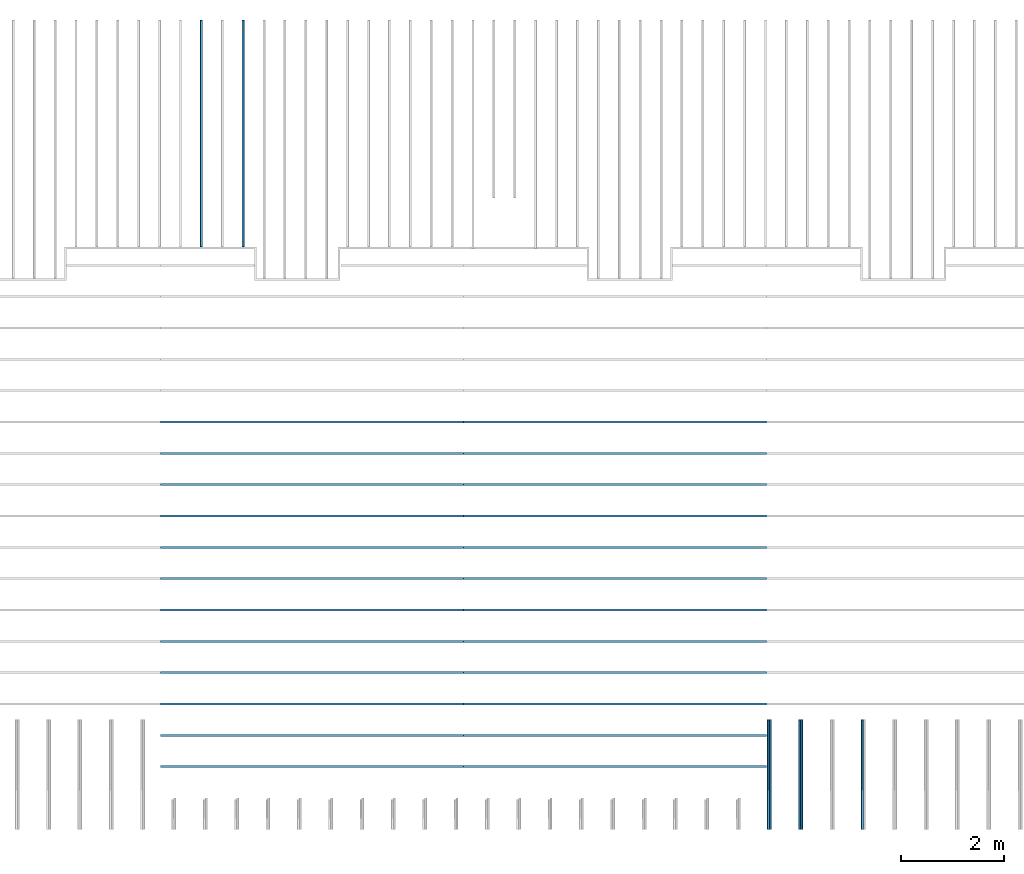
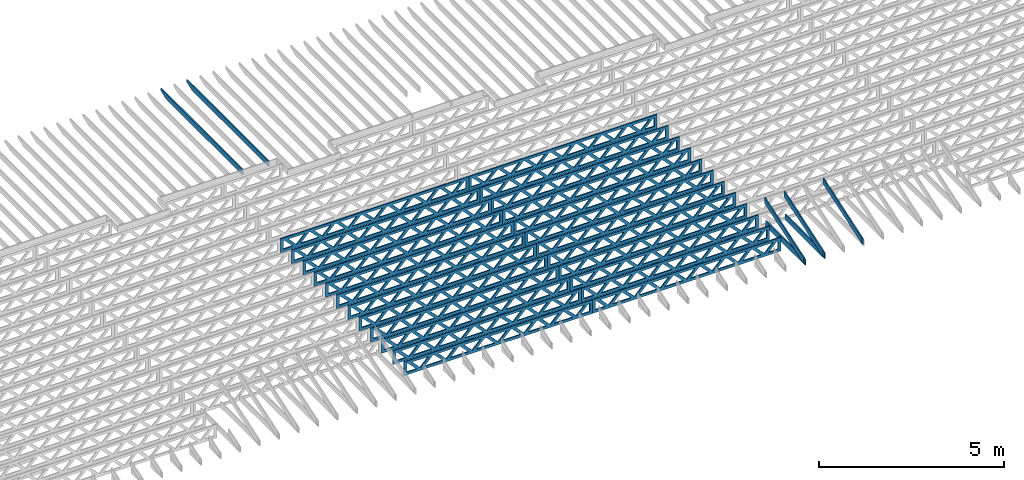
# One storey, part 7 of 18: 31 beams, 5 elements without a shape of their own.
"""IFC4 building model written with IfcOpenShell, lengths in feet."""

import ifcopenshell
import ifcopenshell.guid

model = None  # the IFC model being written
_history = None  # IfcOwnerHistory: only IFC2X3 demands one
_inside = {}  # id of a spatial element -> (the spatial element, [elements in it])
_under = {}  # id of a project, library or spatial element -> (it, [spatial elements below it])
_declared = {}  # id of a project -> (the project, [libraries it declares])
_typed = {}  # id of a type object -> (the type object, [elements of that type])
_made_of = {}  # id of a material, layer set ... -> (it, [elements and type objects made of it])


def new_model(schema):
    """Start an empty IFC model of exactly this schema.

    Asked for "IFC4X3", IfcOpenShell would pick the latest addendum, in which some entities
    have other attributes; the version numbers below select the first issue.
    IFC2X3 requires an IfcOwnerHistory on every rooted entity: one is made here for all.
    """
    global model, _history
    if schema == "IFC4X3":
        model = ifcopenshell.file(schema_version=(4, 3, 0, 0))
    else:
        model = ifcopenshell.file(schema=schema)
    _inside.clear()
    _under.clear()
    _declared.clear()
    _typed.clear()
    _made_of.clear()
    _history = None
    if model.schema == "IFC2X3":
        org = make("IfcOrganization", Name="unknown")
        user = make(
            "IfcPersonAndOrganization",
            ThePerson=make("IfcPerson", FamilyName="unknown"),
            TheOrganization=org,
        )
        app = make(
            "IfcApplication",
            ApplicationDeveloper=org,
            Version="unknown",
            ApplicationFullName="unknown",
            ApplicationIdentifier="unknown",
        )
        _history = make(
            "IfcOwnerHistory",
            OwningUser=user,
            OwningApplication=app,
            ChangeAction="ADDED",
            CreationDate=0,
        )
    return model


def make(cls, **values):
    """One entity of the class cls with the attributes given. An attribute that is None is left unset."""
    return model.create_entity(
        cls, **{name: value for name, value in values.items() if value is not None}
    )


def entity(cls, *values):
    """Any entity or typed value of the class cls, its attributes in the order of the schema. None: left unset."""
    e = model.create_entity(cls)
    for i, value in enumerate(values):
        if value is not None:
            e[i] = value
    return e


def rooted(cls, **values):
    """An entity with a GlobalId (a new one), such as an element, a storey or a relation."""
    return make(cls, GlobalId=ifcopenshell.guid.new(), OwnerHistory=_history, **values)


def si_unit(unit_type, name, prefix=None):
    """IfcSIUnit, for example si_unit("LENGTHUNIT", "METRE", prefix="MILLI")."""
    return make("IfcSIUnit", UnitType=unit_type, Prefix=prefix, Name=name)


def converted_unit(unit_type, name, factor, base, dimensions=None, offset=None):
    """IfcConversionBasedUnit, such as the inch: factor (a typed value) times the base unit."""
    return make(
        "IfcConversionBasedUnit"
        if offset is None
        else "IfcConversionBasedUnitWithOffset",
        ConversionOffset=offset,
        Dimensions=None
        if dimensions is None
        else entity("IfcDimensionalExponents", *dimensions),
        UnitType=unit_type,
        Name=name,
        ConversionFactor=make(
            "IfcMeasureWithUnit", ValueComponent=factor, UnitComponent=base
        ),
    )


def derived_unit(unit_type, elements):
    """IfcDerivedUnit: a product of units, each with its exponent."""
    return make(
        "IfcDerivedUnit",
        Elements=[
            make("IfcDerivedUnitElement", Unit=unit, Exponent=power)
            for unit, power in elements
        ],
        UnitType=unit_type,
    )


def assignment(units):
    """IfcUnitAssignment: the units of a project."""
    return None if units is None else make("IfcUnitAssignment", Units=units)


def point(xyz):
    """IfcCartesianPoint."""
    return None if xyz is None else make("IfcCartesianPoint", Coordinates=xyz)


def direction(xyz):
    """IfcDirection."""
    return None if xyz is None else make("IfcDirection", DirectionRatios=xyz)


def frame(location, z_axis=None, x_axis=None):
    """IfcAxis2Placement3D, a coordinate frame: its origin and axes. An axis left out is left unset."""
    return make(
        "IfcAxis2Placement3D",
        Location=point(location),
        Axis=direction(z_axis),
        RefDirection=direction(x_axis),
    )


def frame_2d(location, x_axis=None):
    """IfcAxis2Placement2D, a coordinate frame in the plane: its origin and x axis."""
    return make(
        "IfcAxis2Placement2D", Location=point(location), RefDirection=direction(x_axis)
    )


def origin():
    """The frame at (0, 0, 0) with its axes left unset."""
    return frame((0.0, 0.0, 0.0))


def origin_2d_with_axis():
    """The frame at (0, 0) in the plane with the x axis (1, 0) written out."""
    return frame_2d((0.0, 0.0), x_axis=(1.0, 0.0))


def place(relative_to, where):
    """IfcLocalPlacement: puts the frame where relative to a parent placement (None: the world)."""
    return make(
        "IfcLocalPlacement", PlacementRelTo=relative_to, RelativePlacement=where
    )


def context(
    kind, dimensions, precision=None, world=None, true_north=None, identifier=None
):
    """IfcGeometricRepresentationContext, for example the 3D "Model" context."""
    return make(
        "IfcGeometricRepresentationContext",
        ContextIdentifier=identifier,
        ContextType=kind,
        CoordinateSpaceDimension=dimensions,
        Precision=precision,
        WorldCoordinateSystem=world,
        TrueNorth=true_north,
    )


def subcontext(parent, identifier, kind, view, scale=None):
    """IfcGeometricRepresentationSubContext, for example "Body" below "Model"."""
    return make(
        "IfcGeometricRepresentationSubContext",
        ContextIdentifier=identifier,
        ContextType=kind,
        ParentContext=parent,
        TargetScale=scale,
        TargetView=view,
    )


def project(units=None, contexts=None):
    """IfcProject with its units and contexts."""
    return rooted(
        "IfcProject",
        Name="project",
        RepresentationContexts=contexts,
        UnitsInContext=assignment(units),
    )


def spatial(cls, under=None, at=None, **own):
    """A site, building, storey or space (cls), placed at a placement, below another one or the project."""
    s = rooted(cls, ObjectPlacement=at, **own)
    if under is not None:
        _under.setdefault(under.id(), (under, []))[1].append(s)
    return s


def profile(cls, at=None, kind="AREA", **sizes):
    """A parametric profile (cls). Its sizes go by their IFC names, for example OverallWidth=200.0."""
    return make(cls, ProfileType=kind, Position=at, **sizes)


def rectangle(**sizes):
    """IfcRectangleProfileDef."""
    return profile("IfcRectangleProfileDef", **sizes)


def extrude(swept, where, along, depth):
    """IfcExtrudedAreaSolid: the profile swept, set in the frame where, extruded along a direction by depth."""
    return make(
        "IfcExtrudedAreaSolid",
        SweptArea=swept,
        Position=where,
        ExtrudedDirection=direction(along),
        Depth=depth,
    )


def clip(a, b, op="DIFFERENCE"):
    """IfcBooleanClippingResult: the solid a cut by the half space b."""
    return make(
        "IfcBooleanClippingResult", Operator=op, FirstOperand=a, SecondOperand=b
    )


def halfspace(plane, agree):
    """IfcHalfSpaceSolid: all space on one side of the plane z = 0 of the frame plane."""
    return make(
        "IfcHalfSpaceSolid",
        BaseSurface=make("IfcPlane", Position=plane),
        AgreementFlag=agree,
    )


def shape(context_of_items, identifier, shape_type, items):
    """IfcShapeRepresentation: the items that make up one representation, for example the "Body"."""
    return make(
        "IfcShapeRepresentation",
        ContextOfItems=context_of_items,
        RepresentationIdentifier=identifier,
        RepresentationType=shape_type,
        Items=items,
    )


def source(mapping_origin, context_of_items, identifier, shape_type, items):
    """IfcRepresentationMap: a shape defined once, which mapped items show again and again."""
    return make(
        "IfcRepresentationMap",
        MappingOrigin=mapping_origin,
        MappedRepresentation=shape(context_of_items, identifier, shape_type, items),
    )


def transform(
    local_origin,
    x_axis=None,
    y_axis=None,
    z_axis=None,
    scale=None,
    scale2=None,
    scale3=None,
    uniform=True,
):
    """IfcCartesianTransformationOperator3D, or its non-uniform kind. x_axis, y_axis, z_axis: its Axis1, 2, 3."""
    if uniform:
        return make(
            "IfcCartesianTransformationOperator3D",
            Axis1=direction(x_axis),
            Axis2=direction(y_axis),
            LocalOrigin=point(local_origin),
            Scale=scale,
            Axis3=direction(z_axis),
        )
    return make(
        "IfcCartesianTransformationOperator3DnonUniform",
        Axis1=direction(x_axis),
        Axis2=direction(y_axis),
        LocalOrigin=point(local_origin),
        Scale=scale,
        Axis3=direction(z_axis),
        Scale2=scale2,
        Scale3=scale3,
    )


def mapped(mapping_source, mapping_target):
    """IfcMappedItem: shows the shape of a source again, moved by a transform."""
    return make(
        "IfcMappedItem", MappingSource=mapping_source, MappingTarget=mapping_target
    )


def material(Name=None, Category=None):
    """IfcMaterial."""
    return make("IfcMaterial", Name=Name, Category=Category)


def material_profile(
    of_material, cross_section, Name=None, Category=None, Priority=None
):
    """IfcMaterialProfile: a cross section and its material."""
    return make(
        "IfcMaterialProfile",
        Name=Name,
        Material=of_material,
        Profile=cross_section,
        Priority=Priority,
        Category=Category,
    )


def profile_set(profiles, Name=None, composite=None):
    """IfcMaterialProfileSet."""
    return make(
        "IfcMaterialProfileSet",
        Name=Name,
        MaterialProfiles=profiles,
        CompositeProfile=composite,
    )


def profile_usage(for_profile_set, cardinal=None, extent=None):
    """IfcMaterialProfileSetUsage: how a profile set lies along its element."""
    return make(
        "IfcMaterialProfileSetUsage",
        ForProfileSet=for_profile_set,
        CardinalPoint=cardinal,
        ReferenceExtent=extent,
    )


def made_of(thing, what):
    """Note that an element or type object is made of a material, layer set ...; save() writes the relation."""
    if what is not None:
        _made_of.setdefault(what.id(), (what, []))[1].append(thing)
    return thing


def type_object(cls, material=None, **own):
    """A type object (cls), such as IfcWallType, which elements share."""
    return made_of(rooted(cls, **own), material)


def type_shapes(of_type, sources):
    """Give a type object the sources (RepresentationMaps) that its elements show as mapped items."""
    of_type.RepresentationMaps = sources


def element(
    cls,
    number,
    at=None,
    inside=None,
    cuts=None,
    type_object=None,
    material=None,
    context=None,
    identifier="Body",
    shape_type=None,
    held_by="IfcProductDefinitionShape",
    body=None,
    shapes=None,
    **own,
):
    """One element of the class cls, such as IfcWall. Its Tag is "e" and its number.

    at: its placement. inside: the storey or other place that contains it. cuts: it is an
    opening in that element (IfcRelVoidsElement). A single representation is given by context,
    identifier, shape_type and body (its items); several are given by shapes. held_by: the class
    of the entity that holds the representations. save() writes the other relations.
    """
    e = rooted(cls, Tag="e%d" % number, ObjectPlacement=at, **own)
    if body is not None:
        shapes = [shape(context, identifier, shape_type, body)]
    if shapes is not None:
        e.Representation = make(held_by, Representations=shapes)
    if inside is not None:
        _inside.setdefault(inside.id(), (inside, []))[1].append(e)
    if cuts is not None:
        rooted(
            "IfcRelVoidsElement", RelatingBuildingElement=cuts, RelatedOpeningElement=e
        )
    if type_object is not None:
        _typed.setdefault(type_object.id(), (type_object, []))[1].append(e)
    return made_of(e, material)


def aggregate(whole, parts):
    """IfcRelAggregates: a whole, such as a stair, and the parts it consists of."""
    return rooted("IfcRelAggregates", RelatingObject=whole, RelatedObjects=parts)


def save(model, path):
    """Write the relations noted so far, then the file.

    IfcRelAggregates (storeys below a building ...), IfcRelContainedInSpatialStructure (elements
    in a storey), IfcRelDefinesByType, IfcRelAssociatesMaterial and IfcRelDeclares: one each for
    every whole, place, type object, material and project.
    """
    for whole, parts in _under.values():
        aggregate(whole, parts)
    for where, things in _inside.values():
        rooted(
            "IfcRelContainedInSpatialStructure",
            RelatedElements=things,
            RelatingStructure=where,
        )
    for kind, things in _typed.values():
        rooted("IfcRelDefinesByType", RelatedObjects=things, RelatingType=kind)
    for what, things in _made_of.values():
        rooted("IfcRelAssociatesMaterial", RelatedObjects=things, RelatingMaterial=what)
    for by, libraries in _declared.values():
        rooted("IfcRelDeclares", RelatingContext=by, RelatedDefinitions=libraries)
    model.write(path)


model = new_model("IFC4")

# Units and contexts
model_context_1 = context("Model", 3, precision=0.0001, world=origin(), true_north=direction((6.12303176911189e-17, 1.0)))
model_context_2 = context("Model", 3, precision=0.0001, world=origin(), true_north=direction((6.12303176911189e-17, 1.0)))
body_context = subcontext(model_context_2, "Body", "Model", "MODEL_VIEW")
ifc_project = project(units=[converted_unit("LENGTHUNIT", "FOOT", entity("IfcRatioMeasure", 0.3048), si_unit("LENGTHUNIT", "METRE"), dimensions=[1, 0, 0, 0, 0, 0, 0]), converted_unit("AREAUNIT", "SQUARE FOOT", entity("IfcRatioMeasure", 0.09290304), si_unit("AREAUNIT", "SQUARE_METRE"), dimensions=[2, 0, 0, 0, 0, 0, 0]), converted_unit("VOLUMEUNIT", "CUBIC FOOT", entity("IfcRatioMeasure", 0.028316846592), si_unit("VOLUMEUNIT", "CUBIC_METRE"), dimensions=[3, 0, 0, 0, 0, 0, 0]), converted_unit("PLANEANGLEUNIT", "DEGREE", entity("IfcRatioMeasure", 0.0174532925199433), si_unit("PLANEANGLEUNIT", "RADIAN"), dimensions=[0, 0, 0, 0, 0, 0, 0]), si_unit("MASSUNIT", "GRAM", prefix="KILO"), derived_unit("MASSDENSITYUNIT", [(si_unit("MASSUNIT", "GRAM", prefix="KILO"), 1), (si_unit("LENGTHUNIT", "METRE"), -3)]), derived_unit("MOMENTOFINERTIAUNIT", [(si_unit("LENGTHUNIT", "METRE"), 4)]), si_unit("TIMEUNIT", "SECOND"), si_unit("FREQUENCYUNIT", "HERTZ"), si_unit("THERMODYNAMICTEMPERATUREUNIT", "DEGREE_CELSIUS"), derived_unit("THERMALTRANSMITTANCEUNIT", [(si_unit("MASSUNIT", "GRAM", prefix="KILO"), 1), (si_unit("THERMODYNAMICTEMPERATUREUNIT", "KELVIN"), -1), (si_unit("TIMEUNIT", "SECOND"), -3)]), derived_unit("VOLUMETRICFLOWRATEUNIT", [(si_unit("LENGTHUNIT", "METRE"), 3), (si_unit("TIMEUNIT", "SECOND"), -1)]), si_unit("ELECTRICCURRENTUNIT", "AMPERE"), si_unit("ELECTRICVOLTAGEUNIT", "VOLT"), si_unit("POWERUNIT", "WATT"), si_unit("FORCEUNIT", "NEWTON"), si_unit("ILLUMINANCEUNIT", "LUX"), si_unit("LUMINOUSFLUXUNIT", "LUMEN"), si_unit("LUMINOUSINTENSITYUNIT", "CANDELA"), derived_unit("USERDEFINED", [(si_unit("MASSUNIT", "GRAM", prefix="KILO"), -1), (si_unit("LENGTHUNIT", "METRE"), -2), (si_unit("TIMEUNIT", "SECOND"), 3), (si_unit("LUMINOUSFLUXUNIT", "LUMEN"), 1)]), derived_unit("LINEARVELOCITYUNIT", [(si_unit("LENGTHUNIT", "METRE"), 1), (si_unit("TIMEUNIT", "SECOND"), -1)]), si_unit("PRESSUREUNIT", "PASCAL"), derived_unit("USERDEFINED", [(si_unit("LENGTHUNIT", "METRE"), -2), (si_unit("MASSUNIT", "GRAM", prefix="KILO"), 1), (si_unit("TIMEUNIT", "SECOND"), -2)]), derived_unit("LINEARFORCEUNIT", [(si_unit("MASSUNIT", "GRAM", prefix="KILO"), 1), (si_unit("LENGTHUNIT", "METRE"), 1), (si_unit("TIMEUNIT", "SECOND"), -2), (si_unit("LENGTHUNIT", "METRE"), -1)]), derived_unit("PLANARFORCEUNIT", [(si_unit("MASSUNIT", "GRAM", prefix="KILO"), 1), (si_unit("LENGTHUNIT", "METRE"), 1), (si_unit("TIMEUNIT", "SECOND"), -2), (si_unit("LENGTHUNIT", "METRE"), -2)])], contexts=[model_context_1])

# Site, building, storey
site_placement = place(None, origin())
site = spatial("IfcSite", under=ifc_project, at=site_placement, CompositionType="ELEMENT")
building_placement = place(site_placement, origin())
building = spatial("IfcBuilding", under=site, at=building_placement, CompositionType="ELEMENT")
storey_placement = place(building_placement, frame((0.0, 0.0, 30.4375000000082)))
storey = spatial("IfcBuildingStorey", under=building, at=storey_placement, Name="ROOF", CompositionType="ELEMENT", Elevation=30.4375000000082)

# Assembly, beams
assembly_1_placement = place(storey_placement, origin())
assembly_1 = element("IfcElementAssembly", 1, at=assembly_1_placement, inside=storey, Name="Structural Beam System:Structural Framing System", ObjectType="Structural Beam System:Structural Framing System", AssemblyPlace="NOTDEFINED", PredefinedType="BEAM_GRID")
ifc_material_1 = material(Name="2X ROOF JOISTS - EXT. STAIN-1 - SEE LIFE SAFETY", Category="Materials")
ifc_material_profile_1 = material_profile(ifc_material_1, rectangle(XDim=0.604166666666667, YDim=0.125000000000011, at=frame_2d((0.0, 0.0), x_axis=(0.0, 1.0))))
ifc_profile_set_1 = profile_set([ifc_material_profile_1])
ifc_profile_usage_1 = profile_usage(ifc_profile_set_1, cardinal=8)
beam_type_1 = type_object("IfcBeamType", PredefinedType="BEAM", material=ifc_profile_set_1)
shared_shape_1 = source(origin(), body_context, "Body", "Clipping", [
    clip(extrude(rectangle(XDim=0.604166666666667, YDim=0.125000000000011, at=frame_2d((0.0, 0.0), x_axis=(0.0, 1.0))), frame((-7.24296317045162, 0.0, 0.0), z_axis=(1.0, 0.0, 0.0), x_axis=(0.0, 1.0, 0.0)), (0.0, 0.0, 1.0), 14.4859263409032), halfspace(frame((-6.26989825106139, -0.0625000000000026, -0.30208333333334), z_axis=(-0.34202014332567, 0.0, -0.939692620785908), x_axis=(0.0, 1.0, 0.0)), False)),
])
type_shapes(beam_type_1, [shared_shape_1])
beam_1_placement = place(assembly_1_placement, frame((-217.133993818795, 966.271567861263, 1.07291666665832), z_axis=(0.0, 0.0, 1.0), x_axis=(0.0, -1.0, 0.0)))
beam_1 = element("IfcBeam", 2, at=beam_1_placement, type_object=beam_type_1, material=ifc_profile_usage_1, PredefinedType="BEAM", context=body_context, shape_type="MappedRepresentation", body=[
    mapped(shared_shape_1, transform((0.0, 0.0, 0.0), scale=1.0)),
])
ifc_profile_usage_2 = profile_usage(ifc_profile_set_1, cardinal=8)
beam_type_2 = type_object("IfcBeamType", PredefinedType="BEAM", material=ifc_profile_set_1)
shared_shape_2 = source(origin(), body_context, "Body", "Clipping", [
    clip(extrude(rectangle(XDim=0.604166666666667, YDim=0.125000000000011, at=frame_2d((0.0, -5.55111512312578e-17), x_axis=(0.0, 1.0))), frame((-7.24296347064075, 0.0, 0.0), z_axis=(1.0, 0.0, 0.0), x_axis=(0.0, 1.0, 0.0)), (0.0, 0.0, 1.0), 14.4859269412815), halfspace(frame((-6.26989855125052, -0.0625000000000026, -0.30208333333334), z_axis=(-0.34202014332567, 0.0, -0.939692620785908), x_axis=(0.0, 1.0, 0.0)), False)),
])
type_shapes(beam_type_2, [shared_shape_2])
beam_2_placement = place(assembly_1_placement, frame((-219.800660485462, 966.271567559738, 1.07291666665832), z_axis=(0.0, 0.0, 1.0), x_axis=(0.0, -1.0, 0.0)))
beam_2 = element("IfcBeam", 3, at=beam_2_placement, type_object=beam_type_2, material=ifc_profile_usage_2, PredefinedType="BEAM", context=body_context, shape_type="MappedRepresentation", body=[
    mapped(shared_shape_2, transform((0.0, 0.0, 0.0), scale=1.0)),
])
aggregate(assembly_1, [beam_1, beam_2])

assembly_2_placement = place(storey_placement, origin())
assembly_2 = element("IfcElementAssembly", 4, at=assembly_2_placement, inside=storey, Name="Structural Beam System:Structural Framing System", ObjectType="Structural Beam System:Structural Framing System", AssemblyPlace="NOTDEFINED", PredefinedType="BEAM_GRID")
ifc_material_2 = material(Name="TOP CHORD OF FIELD FRAMED OVERHANG", Category="Materials")
ifc_material_profile_2 = material_profile(ifc_material_2, rectangle(XDim=0.604166666666667, YDim=0.125, at=origin_2d_with_axis()), Name="2X8 TOP CHORD")
ifc_profile_set_2 = profile_set([ifc_material_profile_2], Name="2X8 TOP CHORD")
ifc_profile_usage_3 = profile_usage(ifc_profile_set_2, cardinal=8)
beam_type_3 = type_object("IfcBeamType", Name="Dimension Lumber - Ends:2X8 TOP CHORD", PredefinedType="BEAM", material=ifc_profile_set_2)
shared_shape_3 = source(origin(), body_context, "Body", "Clipping", [
    clip(clip(extrude(rectangle(XDim=0.604166666666667, YDim=0.125, at=origin_2d_with_axis()), frame((-3.68931731846402, 0.0, 0.0), z_axis=(1.0, 0.0, 0.0), x_axis=(0.0, 0.0, -1.0)), (0.0, 0.0, 1.0), 7.5799655454405), halfspace(frame((3.68931731846399, -0.0625000000000025, -0.302083333333339), z_axis=(0.948710608132914, 0.0, -0.316145823973806), x_axis=(0.0, 1.0, 0.0)), False)), halfspace(frame((-3.48798640995154, -0.0625000000000025, 0.302083333333328), z_axis=(-0.948710608132914, 0.0, 0.316145823973807), x_axis=(0.0, 1.0, 0.0)), False)),
])
type_shapes(beam_type_3, [shared_shape_3])
beam_3_placement = place(assembly_2_placement, frame((-181.613158541548, 925.266385711858, 2.43688541345608), z_axis=(0.0, -0.316227766016854, 0.948683298050508), x_axis=(0.0, 0.948683298050508, 0.316227766016854)))
beam_3 = element("IfcBeam", 5, at=beam_3_placement, type_object=beam_type_3, material=ifc_profile_usage_3, Name="Dimension Lumber - Ends:2X8 TOP CHORD", ObjectType="Dimension Lumber - Ends:2X8 TOP CHORD", PredefinedType="BEAM", context=body_context, shape_type="MappedRepresentation", body=[
    mapped(shared_shape_3, transform((0.0, 0.0, 0.0), scale=1.0)),
])
ifc_profile_usage_4 = profile_usage(ifc_profile_set_2, cardinal=8)
beam_4_placement = place(assembly_2_placement, frame((-177.613158541547, 925.266385711858, 2.43688541345608), z_axis=(0.0, -0.316227766016854, 0.948683298050508), x_axis=(0.0, 0.948683298050508, 0.316227766016854)))
beam_4 = element("IfcBeam", 6, at=beam_4_placement, type_object=beam_type_3, material=ifc_profile_usage_4, Name="Dimension Lumber - Ends:2X8 TOP CHORD", ObjectType="Dimension Lumber - Ends:2X8 TOP CHORD", PredefinedType="BEAM", context=body_context, shape_type="MappedRepresentation", body=[
    mapped(shared_shape_3, transform((0.0, 0.0, 0.0), scale=1.0)),
])
ifc_profile_usage_5 = profile_usage(ifc_profile_set_2, cardinal=8)
beam_5_placement = place(assembly_2_placement, frame((-183.613158541548, 925.266385711858, 2.4368854134562), z_axis=(0.0, -0.316227766016853, 0.948683298050509), x_axis=(0.0, 0.948683298050509, 0.316227766016853)))
beam_5 = element("IfcBeam", 7, at=beam_5_placement, type_object=beam_type_3, material=ifc_profile_usage_5, Name="Dimension Lumber - Ends:2X8 TOP CHORD", ObjectType="Dimension Lumber - Ends:2X8 TOP CHORD", PredefinedType="BEAM", context=body_context, shape_type="MappedRepresentation", body=[
    mapped(shared_shape_3, transform((0.0, 0.0, 0.0), scale=1.0)),
])
aggregate(assembly_2, [beam_3, beam_4, beam_5])

assembly_3_placement = place(storey_placement, origin())
assembly_3 = element("IfcElementAssembly", 8, at=assembly_3_placement, inside=storey, Name="Structural Beam System:Structural Framing System", ObjectType="Structural Beam System:Structural Framing System", AssemblyPlace="NOTDEFINED", PredefinedType="BEAM_GRID")
ifc_material_3 = material(Name="BOTTOM CHORD OF FIELD FRAMED OVERHANG", Category="Materials")
ifc_material_profile_3 = material_profile(ifc_material_3, rectangle(XDim=0.604166666666667, YDim=0.125000000000011, at=origin_2d_with_axis()), Name="2X8 - BOTTOM CHORD")
ifc_profile_set_3 = profile_set([ifc_material_profile_3], Name="2X8 - BOTTOM CHORD")
ifc_profile_usage_6 = profile_usage(ifc_profile_set_3, cardinal=8)
beam_type_4 = type_object("IfcBeamType", Name="061100 - Wood Framing:2X8 - BOTTOM CHORD", PredefinedType="BEAM", material=ifc_profile_set_3)
shared_shape_4 = source(origin(), body_context, "Body", "SweptSolid", [
    extrude(rectangle(XDim=0.604166666666667, YDim=0.125000000000011, at=origin_2d_with_axis()), frame((-3.49999999999926, 0.0, 0.0), z_axis=(1.0, 0.0, 0.0), x_axis=(0.0, 0.0, -1.0)), (0.0, 0.0, 1.0), 6.99999999999852),
])
type_shapes(beam_type_4, [shared_shape_4])
beam_6_placement = place(assembly_3_placement, frame((-183.488158437574, 925.361939802883, 1.07291666665406), z_axis=(0.0, 0.0, 1.0), x_axis=(0.0, -1.0, 0.0)))
beam_6 = element("IfcBeam", 9, at=beam_6_placement, type_object=beam_type_4, material=ifc_profile_usage_6, Name="061100 - Wood Framing:2X8 - BOTTOM CHORD", ObjectType="061100 - Wood Framing:2X8 - BOTTOM CHORD", PredefinedType="BEAM", context=body_context, shape_type="MappedRepresentation", body=[
    mapped(shared_shape_4, transform((0.0, 0.0, 0.0), scale=1.0)),
])
ifc_profile_usage_7 = profile_usage(ifc_profile_set_3, cardinal=8)
beam_7_placement = place(assembly_3_placement, frame((-181.488158437574, 925.361940305387, 1.07291666665406), z_axis=(0.0, 0.0, 1.0), x_axis=(0.0, -1.0, 0.0)))
beam_7 = element("IfcBeam", 10, at=beam_7_placement, type_object=beam_type_4, material=ifc_profile_usage_7, Name="061100 - Wood Framing:2X8 - BOTTOM CHORD", ObjectType="061100 - Wood Framing:2X8 - BOTTOM CHORD", PredefinedType="BEAM", context=body_context, shape_type="MappedRepresentation", body=[
    mapped(shared_shape_4, transform((0.0, 0.0, 0.0), scale=1.0)),
])
aggregate(assembly_3, [beam_6, beam_7])

assembly_4_placement = place(storey_placement, origin())
assembly_4 = element("IfcElementAssembly", 11, at=assembly_4_placement, inside=storey, Name="Structural Beam System:Structural Framing System", ObjectType="Structural Beam System:Structural Framing System", AssemblyPlace="NOTDEFINED", PredefinedType="BEAM_GRID")
ifc_material_4 = material(Name="WOOD TRUSS", Category="Materials")
ifc_material_profile_4 = material_profile(ifc_material_4, rectangle(XDim=1.73473973950632, YDim=0.125, at=origin_2d_with_axis()))
ifc_material_profile_5 = material_profile(ifc_material_4, rectangle(XDim=1.73473973950633, YDim=0.125, at=frame_2d((-1.11022302462516e-16, 0.0), x_axis=(1.0, 0.0))))
ifc_material_profile_6 = material_profile(ifc_material_4, rectangle(XDim=1.73473973950632, YDim=0.125, at=origin_2d_with_axis()))
ifc_material_profile_7 = material_profile(ifc_material_4, rectangle(XDim=1.73473973950633, YDim=0.125, at=origin_2d_with_axis()))
ifc_material_profile_8 = material_profile(ifc_material_4, rectangle(XDim=1.73473973950632, YDim=0.125, at=frame_2d((-5.55111512312578e-17, 0.0), x_axis=(1.0, 0.0))))
ifc_material_profile_9 = material_profile(ifc_material_4, rectangle(XDim=1.73473973950633, YDim=0.125, at=frame_2d((-2.77555756156289e-16, 0.0), x_axis=(1.0, 0.0))))
ifc_material_profile_10 = material_profile(ifc_material_4, rectangle(XDim=1.73473973950632, YDim=0.125, at=frame_2d((-4.9960036108132e-16, 0.0), x_axis=(1.0, 0.0))))
ifc_material_profile_11 = material_profile(ifc_material_4, rectangle(XDim=1.73473973950633, YDim=0.125, at=frame_2d((4.44089209850063e-16, 0.0), x_axis=(1.0, 0.0))))
ifc_material_profile_12 = material_profile(ifc_material_4, rectangle(XDim=1.73473973950632, YDim=0.125, at=origin_2d_with_axis()))
ifc_material_profile_13 = material_profile(ifc_material_4, rectangle(XDim=1.73473973950633, YDim=0.125, at=frame_2d((-4.9960036108132e-16, 0.0), x_axis=(1.0, 0.0))))
ifc_material_profile_14 = material_profile(ifc_material_4, rectangle(XDim=0.291666666666664, YDim=0.125, at=frame_2d((-2.77555756156289e-17, 0.0), x_axis=(1.0, 0.0))))
ifc_material_profile_15 = material_profile(ifc_material_4, rectangle(XDim=0.291666666666628, YDim=0.124999999999995, at=frame_2d((-5.55111512312578e-17, 0.0), x_axis=(1.0, 0.0))))
ifc_material_profile_16 = material_profile(ifc_material_4, rectangle(XDim=0.916666666666666, YDim=0.125000000000003, at=frame_2d((-2.77555756156289e-17, 0.0), x_axis=(1.0, 0.0))))
ifc_material_profile_17 = material_profile(ifc_material_4, rectangle(XDim=0.916666666666651, YDim=0.125, at=frame_2d((-2.77555756156289e-17, 0.0), x_axis=(1.0, 0.0))))
ifc_profile_set_4 = profile_set([ifc_material_profile_4, ifc_material_profile_5, ifc_material_profile_6, ifc_material_profile_7, ifc_material_profile_8, ifc_material_profile_9, ifc_material_profile_10, ifc_material_profile_11, ifc_material_profile_12, ifc_material_profile_13, ifc_material_profile_14, ifc_material_profile_15, ifc_material_profile_16, ifc_material_profile_17])
ifc_profile_usage_8 = profile_usage(ifc_profile_set_4, cardinal=8)
beam_type_5 = type_object("IfcBeamType", PredefinedType="BEAM", material=ifc_profile_set_4)
shared_shape_5 = source(origin(), body_context, "Body", "SweptSolid", [
    extrude(rectangle(XDim=1.73473973950632, YDim=0.125, at=frame_2d((-5.55111512312578e-16, 0.0), x_axis=(1.0, 0.0))), frame((5.85339326404794, 0.0, 0.101118361020562), z_axis=(0.720569184836762, 0.0, -0.693383046997606), x_axis=(0.693383046997606, 0.0, 0.720569184836762)), (0.0, 0.0, 1.0), 0.291666666666667),
    extrude(rectangle(XDim=1.73473973950633, YDim=0.125, at=frame_2d((-4.9960036108132e-16, 0.0), x_axis=(1.0, 0.0))), frame((4.60310739037467, 0.0, -0.101118361020407), z_axis=(0.720569184836758, 0.0, 0.69338304699761), x_axis=(0.69338304699761, 0.0, -0.720569184836758)), (0.0, 0.0, 1.0), 0.291666666666667),
    extrude(rectangle(XDim=1.73473973950632, YDim=0.125, at=frame_2d((3.33066907387547e-16, 0.0), x_axis=(1.0, 0.0))), frame((3.18672659738144, 0.0, 0.101118361020562), z_axis=(0.720569184836762, 0.0, -0.693383046997606), x_axis=(0.693383046997606, 0.0, 0.720569184836762)), (0.0, 0.0, 1.0), 0.291666666666667),
    extrude(rectangle(XDim=1.73473973950633, YDim=0.125, at=frame_2d((-1.11022302462516e-16, 0.0), x_axis=(1.0, 0.0))), frame((1.93644072370817, 0.0, -0.101118361020407), z_axis=(0.720569184836758, 0.0, 0.69338304699761), x_axis=(0.69338304699761, 0.0, -0.720569184836758)), (0.0, 0.0, 1.0), 0.291666666666666),
    extrude(rectangle(XDim=1.73473973950632, YDim=0.125, at=frame_2d((5.55111512312578e-17, 0.0), x_axis=(1.0, 0.0))), frame((0.520059930714937, 0.0, 0.101118361020562), z_axis=(0.720569184836762, 0.0, -0.693383046997606), x_axis=(0.693383046997606, 0.0, 0.720569184836762)), (0.0, 0.0, 1.0), 0.291666666666667),
    extrude(rectangle(XDim=1.73473973950633, YDim=0.125, at=origin_2d_with_axis()), frame((-0.730225942958334, 0.0, -0.101118361020407), z_axis=(0.720569184836758, 0.0, 0.69338304699761), x_axis=(0.69338304699761, 0.0, -0.720569184836758)), (0.0, 0.0, 1.0), 0.291666666666666),
    extrude(rectangle(XDim=1.73473973950632, YDim=0.125, at=frame_2d((-5.55111512312578e-17, 0.0), x_axis=(1.0, 0.0))), frame((-2.14660673595157, 0.0, 0.101118361020562), z_axis=(0.720569184836762, 0.0, -0.693383046997606), x_axis=(0.693383046997606, 0.0, 0.720569184836762)), (0.0, 0.0, 1.0), 0.291666666666667),
    extrude(rectangle(XDim=1.73473973950633, YDim=0.125, at=frame_2d((-2.77555756156289e-16, 0.0), x_axis=(1.0, 0.0))), frame((-3.39689260962484, 0.0, -0.101118361020407), z_axis=(0.720569184836758, 0.0, 0.69338304699761), x_axis=(0.69338304699761, 0.0, -0.720569184836758)), (0.0, 0.0, 1.0), 0.291666666666666),
    extrude(rectangle(XDim=1.73473973950632, YDim=0.125, at=origin_2d_with_axis()), frame((-4.81327340261807, 0.0, 0.101118361020562), z_axis=(0.720569184836762, 0.0, -0.693383046997606), x_axis=(0.693383046997606, 0.0, 0.720569184836762)), (0.0, 0.0, 1.0), 0.291666666666667),
    extrude(rectangle(XDim=1.73473973950633, YDim=0.125, at=frame_2d((-4.9960036108132e-16, 0.0), x_axis=(1.0, 0.0))), frame((-6.06355927629134, 0.0, -0.101118361020407), z_axis=(0.720569184836758, 0.0, 0.69338304699761), x_axis=(0.69338304699761, 0.0, -0.720569184836758)), (0.0, 0.0, 1.0), 0.291666666666667),
    extrude(rectangle(XDim=1.73473973950632, YDim=0.125, at=frame_2d((-1.0547118733939e-15, 0.0), x_axis=(1.0, 0.0))), frame((8.52005993071445, 0.0, 0.101118361020506), z_axis=(0.720569184836761, 0.0, -0.693383046997607), x_axis=(0.693383046997607, 0.0, 0.720569184836761)), (0.0, 0.0, 1.0), 0.291666666666667),
    extrude(rectangle(XDim=1.73473973950633, YDim=0.125, at=origin_2d_with_axis()), frame((7.26977405704118, 0.0, -0.101118361020463), z_axis=(0.720569184836758, 0.0, 0.69338304699761), x_axis=(0.69338304699761, 0.0, -0.720569184836758)), (0.0, 0.0, 1.0), 0.291666666666667),
    extrude(rectangle(XDim=1.73473973950632, YDim=0.125, at=frame_2d((4.44089209850063e-16, 0.0), x_axis=(1.0, 0.0))), frame((-7.47994006928457, 0.0, 0.101118361020561), z_axis=(0.720569184836762, 0.0, -0.693383046997606), x_axis=(0.693383046997606, 0.0, 0.720569184836762)), (0.0, 0.0, 1.0), 0.291666666666666),
    extrude(rectangle(XDim=1.73473973950633, YDim=0.125, at=origin_2d_with_axis()), frame((-8.73022594295784, 0.0, -0.101118361020408), z_axis=(0.720569184836758, 0.0, 0.69338304699761), x_axis=(0.69338304699761, 0.0, -0.720569184836758)), (0.0, 0.0, 1.0), 0.291666666666666),
    extrude(rectangle(XDim=0.291666666666664, YDim=0.125, at=frame_2d((-2.77555756156289e-17, 0.0), x_axis=(1.0, 0.0))), frame((-9.66666666666609, 0.0, 0.604166666666611), z_axis=(1.0, 0.0, 0.0), x_axis=(0.0, 0.0, -1.0)), (0.0, 0.0, 1.0), 19.3333333333322),
    extrude(rectangle(XDim=0.291666666666628, YDim=0.124999999999995, at=frame_2d((-5.55111512312578e-17, 0.0), x_axis=(1.0, 0.0))), frame((-9.66666666666588, 0.0, -0.604166666666693), z_axis=(1.0, 0.0, 0.0), x_axis=(0.0, 0.0, -1.0)), (0.0, 0.0, 1.0), 19.333333333332),
    extrude(rectangle(XDim=0.916666666666666, YDim=0.125000000000003, at=frame_2d((-2.77555756156289e-17, 0.0), x_axis=(1.0, 0.0))), frame((9.3749999999994, 0.0, 0.0), z_axis=(1.0, 0.0, 0.0), x_axis=(0.0, 0.0, -1.0)), (0.0, 0.0, 1.0), 0.291666666666687),
    extrude(rectangle(XDim=0.916666666666651, YDim=0.125, at=frame_2d((-2.77555756156289e-17, 0.0), x_axis=(1.0, 0.0))), frame((-9.66666666666609, 0.0, 0.0), z_axis=(1.0, 0.0, 0.0), x_axis=(0.0, 0.0, -1.0)), (0.0, 0.0, 1.0), 0.291666666666687),
])
type_shapes(beam_type_5, [shared_shape_5])
beam_8_placement = place(assembly_4_placement, frame((-212.738160485494, 933.861934882651, 0.749999999991658), z_axis=(0.0, 0.0, 1.0), x_axis=(-1.0, 0.0, 0.0)))
beam_8 = element("IfcBeam", 12, at=beam_8_placement, type_object=beam_type_5, material=ifc_profile_usage_8, PredefinedType="BEAM", context=body_context, shape_type="MappedRepresentation", body=[
    mapped(shared_shape_5, transform((0.0, 0.0, 0.0), scale=1.0)),
])
ifc_profile_usage_9 = profile_usage(ifc_profile_set_4, cardinal=8)
beam_9_placement = place(assembly_4_placement, frame((-212.738160485494, 935.861934882651, 0.749999999991651), z_axis=(0.0, 0.0, 1.0), x_axis=(-1.0, 0.0, 0.0)))
beam_9 = element("IfcBeam", 13, at=beam_9_placement, type_object=beam_type_5, material=ifc_profile_usage_9, PredefinedType="BEAM", context=body_context, shape_type="MappedRepresentation", body=[
    mapped(shared_shape_5, transform((0.0, 0.0, 0.0), scale=1.0)),
])
ifc_profile_usage_10 = profile_usage(ifc_profile_set_4, cardinal=8)
beam_10_placement = place(assembly_4_placement, frame((-212.738160485494, 937.861934882651, 0.749999999991651), z_axis=(0.0, 0.0, 1.0), x_axis=(-1.0, 0.0, 0.0)))
beam_10 = element("IfcBeam", 14, at=beam_10_placement, type_object=beam_type_5, material=ifc_profile_usage_10, PredefinedType="BEAM", context=body_context, shape_type="MappedRepresentation", body=[
    mapped(shared_shape_5, transform((0.0, 0.0, 0.0), scale=1.0)),
])
ifc_profile_usage_11 = profile_usage(ifc_profile_set_4, cardinal=8)
beam_11_placement = place(assembly_4_placement, frame((-212.738160485494, 939.861934882651, 0.749999999991644), z_axis=(0.0, 0.0, 1.0), x_axis=(-1.0, 0.0, 0.0)))
beam_11 = element("IfcBeam", 15, at=beam_11_placement, type_object=beam_type_5, material=ifc_profile_usage_11, PredefinedType="BEAM", context=body_context, shape_type="MappedRepresentation", body=[
    mapped(shared_shape_5, transform((0.0, 0.0, 0.0), scale=1.0)),
])
ifc_profile_usage_12 = profile_usage(ifc_profile_set_4, cardinal=8)
beam_12_placement = place(assembly_4_placement, frame((-212.738160485494, 941.861934882651, 0.749999999991637), z_axis=(0.0, 0.0, 1.0), x_axis=(-1.0, 0.0, 0.0)))
beam_12 = element("IfcBeam", 16, at=beam_12_placement, type_object=beam_type_5, material=ifc_profile_usage_12, PredefinedType="BEAM", context=body_context, shape_type="MappedRepresentation", body=[
    mapped(shared_shape_5, transform((0.0, 0.0, 0.0), scale=1.0)),
])
ifc_profile_usage_13 = profile_usage(ifc_profile_set_4, cardinal=8)
beam_13_placement = place(assembly_4_placement, frame((-212.738160485494, 943.861934882651, 0.74999999999163), z_axis=(0.0, 0.0, 1.0), x_axis=(-1.0, 0.0, 0.0)))
beam_13 = element("IfcBeam", 17, at=beam_13_placement, type_object=beam_type_5, material=ifc_profile_usage_13, PredefinedType="BEAM", context=body_context, shape_type="MappedRepresentation", body=[
    mapped(shared_shape_5, transform((0.0, 0.0, 0.0), scale=1.0)),
])
ifc_profile_usage_14 = profile_usage(ifc_profile_set_4, cardinal=8)
beam_14_placement = place(assembly_4_placement, frame((-212.738160485494, 945.861934882651, 0.74999999999163), z_axis=(0.0, 0.0, 1.0), x_axis=(-1.0, 0.0, 0.0)))
beam_14 = element("IfcBeam", 18, at=beam_14_placement, type_object=beam_type_5, material=ifc_profile_usage_14, PredefinedType="BEAM", context=body_context, shape_type="MappedRepresentation", body=[
    mapped(shared_shape_5, transform((0.0, 0.0, 0.0), scale=1.0)),
])
ifc_profile_usage_15 = profile_usage(ifc_profile_set_4, cardinal=8)
beam_15_placement = place(assembly_4_placement, frame((-212.738160485494, 947.861934882651, 0.749999999991623), z_axis=(0.0, 0.0, 1.0), x_axis=(-1.0, 0.0, 0.0)))
beam_15 = element("IfcBeam", 19, at=beam_15_placement, type_object=beam_type_5, material=ifc_profile_usage_15, PredefinedType="BEAM", context=body_context, shape_type="MappedRepresentation", body=[
    mapped(shared_shape_5, transform((0.0, 0.0, 0.0), scale=1.0)),
])

assembly_5_placement = place(storey_placement, origin())
assembly_5 = element("IfcElementAssembly", 20, at=assembly_5_placement, inside=storey, Name="Structural Beam System:Structural Framing System", ObjectType="Structural Beam System:Structural Framing System", AssemblyPlace="NOTDEFINED", PredefinedType="BEAM_GRID")
ifc_profile_usage_16 = profile_usage(ifc_profile_set_4, cardinal=8)
beam_16_placement = place(assembly_5_placement, frame((-193.404827152229, 927.861934882651, 0.74999999999168)))
beam_16 = element("IfcBeam", 21, at=beam_16_placement, type_object=beam_type_5, material=ifc_profile_usage_16, PredefinedType="BEAM", context=body_context, shape_type="MappedRepresentation", body=[
    mapped(shared_shape_5, transform((0.0, 0.0, 0.0), scale=1.0)),
])
ifc_profile_usage_17 = profile_usage(ifc_profile_set_4, cardinal=8)
beam_17_placement = place(assembly_5_placement, frame((-193.404827152229, 929.861934882651, 0.749999999991672)))
beam_17 = element("IfcBeam", 22, at=beam_17_placement, type_object=beam_type_5, material=ifc_profile_usage_17, PredefinedType="BEAM", context=body_context, shape_type="MappedRepresentation", body=[
    mapped(shared_shape_5, transform((0.0, 0.0, 0.0), scale=1.0)),
])
ifc_profile_usage_18 = profile_usage(ifc_profile_set_4, cardinal=8)
beam_18_placement = place(assembly_5_placement, frame((-193.404827152229, 933.861934882651, 0.749999999991658)))
beam_18 = element("IfcBeam", 23, at=beam_18_placement, type_object=beam_type_5, material=ifc_profile_usage_18, PredefinedType="BEAM", context=body_context, shape_type="MappedRepresentation", body=[
    mapped(shared_shape_5, transform((0.0, 0.0, 0.0), scale=1.0)),
])
ifc_profile_usage_19 = profile_usage(ifc_profile_set_4, cardinal=8)
beam_19_placement = place(assembly_5_placement, frame((-193.404827152229, 943.861934882651, 0.74999999999163)))
beam_19 = element("IfcBeam", 24, at=beam_19_placement, type_object=beam_type_5, material=ifc_profile_usage_19, PredefinedType="BEAM", context=body_context, shape_type="MappedRepresentation", body=[
    mapped(shared_shape_5, transform((0.0, 0.0, 0.0), scale=1.0)),
])
ifc_profile_usage_20 = profile_usage(ifc_profile_set_4, cardinal=8)
beam_20_placement = place(assembly_5_placement, frame((-193.404827152229, 947.861934882651, 0.749999999991623)))
beam_20 = element("IfcBeam", 25, at=beam_20_placement, type_object=beam_type_5, material=ifc_profile_usage_20, PredefinedType="BEAM", context=body_context, shape_type="MappedRepresentation", body=[
    mapped(shared_shape_5, transform((0.0, 0.0, 0.0), scale=1.0)),
])
ifc_profile_usage_21 = profile_usage(ifc_profile_set_4, cardinal=8)
beam_21_placement = place(assembly_5_placement, frame((-193.404827152229, 945.861934882651, 0.74999999999163)))
beam_21 = element("IfcBeam", 26, at=beam_21_placement, type_object=beam_type_5, material=ifc_profile_usage_21, PredefinedType="BEAM", context=body_context, shape_type="MappedRepresentation", body=[
    mapped(shared_shape_5, transform((0.0, 0.0, 0.0), scale=1.0)),
])
ifc_profile_usage_22 = profile_usage(ifc_profile_set_4, cardinal=8)
beam_22_placement = place(assembly_5_placement, frame((-193.404827152229, 941.861934882651, 0.749999999991637)))
beam_22 = element("IfcBeam", 27, at=beam_22_placement, type_object=beam_type_5, material=ifc_profile_usage_22, PredefinedType="BEAM", context=body_context, shape_type="MappedRepresentation", body=[
    mapped(shared_shape_5, transform((0.0, 0.0, 0.0), scale=1.0)),
])
ifc_profile_usage_23 = profile_usage(ifc_profile_set_4, cardinal=8)
beam_23_placement = place(assembly_5_placement, frame((-193.404827152229, 939.861934882651, 0.749999999991644)))
beam_23 = element("IfcBeam", 28, at=beam_23_placement, type_object=beam_type_5, material=ifc_profile_usage_23, PredefinedType="BEAM", context=body_context, shape_type="MappedRepresentation", body=[
    mapped(shared_shape_5, transform((0.0, 0.0, 0.0), scale=1.0)),
])
ifc_profile_usage_24 = profile_usage(ifc_profile_set_4, cardinal=8)
beam_24_placement = place(assembly_5_placement, frame((-193.404827152229, 937.861934882651, 0.749999999991651)))
beam_24 = element("IfcBeam", 29, at=beam_24_placement, type_object=beam_type_5, material=ifc_profile_usage_24, PredefinedType="BEAM", context=body_context, shape_type="MappedRepresentation", body=[
    mapped(shared_shape_5, transform((0.0, 0.0, 0.0), scale=1.0)),
])
ifc_profile_usage_25 = profile_usage(ifc_profile_set_4, cardinal=8)
beam_25_placement = place(assembly_5_placement, frame((-193.404827152229, 935.861934882651, 0.749999999991651)))
beam_25 = element("IfcBeam", 30, at=beam_25_placement, type_object=beam_type_5, material=ifc_profile_usage_25, PredefinedType="BEAM", context=body_context, shape_type="MappedRepresentation", body=[
    mapped(shared_shape_5, transform((0.0, 0.0, 0.0), scale=1.0)),
])
ifc_profile_usage_26 = profile_usage(ifc_profile_set_4, cardinal=8)
beam_26_placement = place(assembly_5_placement, frame((-193.404827152229, 931.861934882651, 0.749999999991665)))
beam_26 = element("IfcBeam", 31, at=beam_26_placement, type_object=beam_type_5, material=ifc_profile_usage_26, PredefinedType="BEAM", context=body_context, shape_type="MappedRepresentation", body=[
    mapped(shared_shape_5, transform((0.0, 0.0, 0.0), scale=1.0)),
])
ifc_profile_usage_27 = profile_usage(ifc_profile_set_4, cardinal=8)
beam_27_placement = place(assembly_5_placement, frame((-193.404827152229, 925.861934882651, 0.74999999999168)))
beam_27 = element("IfcBeam", 32, at=beam_27_placement, type_object=beam_type_5, material=ifc_profile_usage_27, PredefinedType="BEAM", context=body_context, shape_type="MappedRepresentation", body=[
    mapped(shared_shape_5, transform((0.0, 0.0, 0.0), scale=1.0)),
])
aggregate(assembly_5, [beam_16, beam_17, beam_18, beam_19, beam_20, beam_21, beam_22, beam_23, beam_24, beam_25, beam_26, beam_27])

# Beam
ifc_profile_usage_28 = profile_usage(ifc_profile_set_4, cardinal=8)
beam_28_placement = place(assembly_4_placement, frame((-212.738160485494, 931.861934882651, 0.749999999991665), z_axis=(0.0, 0.0, 1.0), x_axis=(-1.0, 0.0, 0.0)))
beam_28 = element("IfcBeam", 33, at=beam_28_placement, type_object=beam_type_5, material=ifc_profile_usage_28, PredefinedType="BEAM", context=body_context, shape_type="MappedRepresentation", body=[
    mapped(shared_shape_5, transform((0.0, 0.0, 0.0), scale=1.0)),
])

ifc_profile_usage_29 = profile_usage(ifc_profile_set_4, cardinal=8)
beam_29_placement = place(assembly_4_placement, frame((-212.738160485494, 929.861934882651, 0.749999999991672), z_axis=(0.0, 0.0, 1.0), x_axis=(-1.0, 0.0, 0.0)))
beam_29 = element("IfcBeam", 34, at=beam_29_placement, type_object=beam_type_5, material=ifc_profile_usage_29, PredefinedType="BEAM", context=body_context, shape_type="MappedRepresentation", body=[
    mapped(shared_shape_5, transform((0.0, 0.0, 0.0), scale=1.0)),
])

ifc_profile_usage_30 = profile_usage(ifc_profile_set_4, cardinal=8)
beam_30_placement = place(assembly_4_placement, frame((-212.738160485494, 927.861934882651, 0.74999999999168), z_axis=(0.0, 0.0, 1.0), x_axis=(-1.0, 0.0, 0.0)))
beam_30 = element("IfcBeam", 35, at=beam_30_placement, type_object=beam_type_5, material=ifc_profile_usage_30, PredefinedType="BEAM", context=body_context, shape_type="MappedRepresentation", body=[
    mapped(shared_shape_5, transform((0.0, 0.0, 0.0), scale=1.0)),
])

ifc_profile_usage_31 = profile_usage(ifc_profile_set_4, cardinal=8)
beam_31_placement = place(assembly_4_placement, frame((-212.738160485494, 925.861934882651, 0.74999999999168), z_axis=(0.0, 0.0, 1.0), x_axis=(-1.0, 0.0, 0.0)))
beam_31 = element("IfcBeam", 36, at=beam_31_placement, type_object=beam_type_5, material=ifc_profile_usage_31, PredefinedType="BEAM", context=body_context, shape_type="MappedRepresentation", body=[
    mapped(shared_shape_5, transform((0.0, 0.0, 0.0), scale=1.0)),
])

aggregate(assembly_4, [beam_8, beam_9, beam_10, beam_11, beam_12, beam_13, beam_14, beam_15, beam_28, beam_29, beam_30, beam_31])

save(model, "model.ifc")
